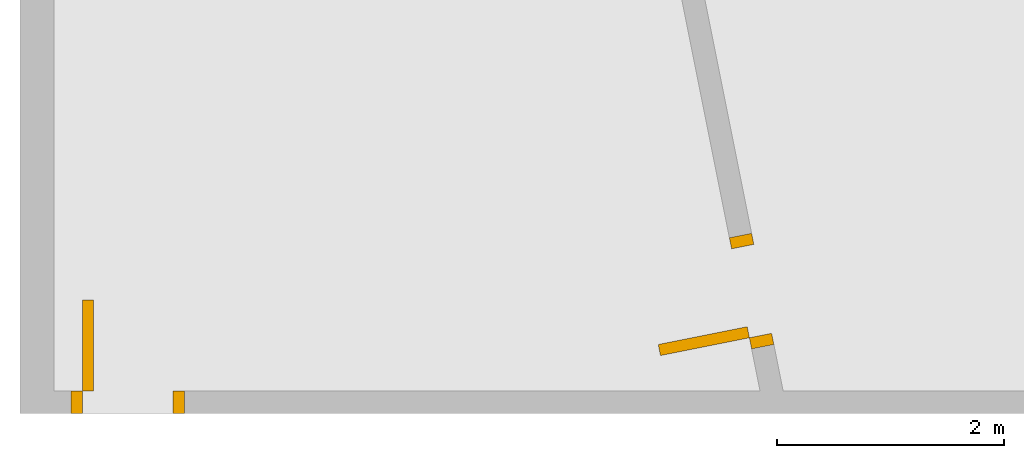
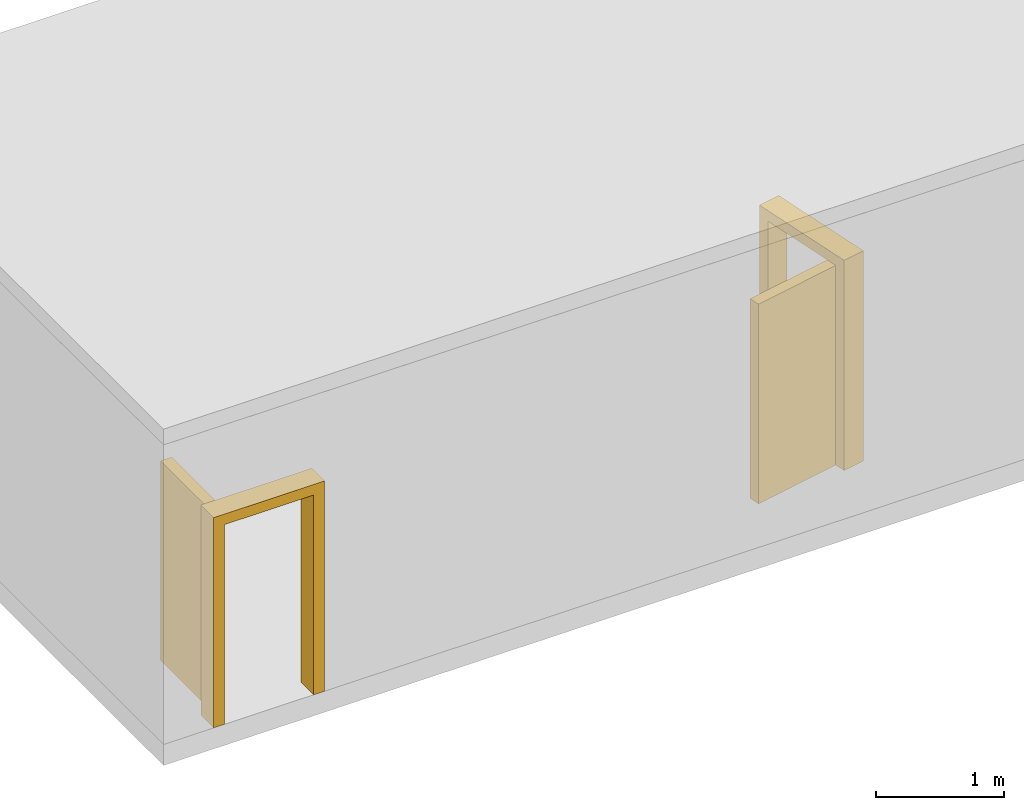
# One storey, part 2 of 3: 2 doors.
"""IFC4 building model written with IfcOpenShell, lengths in metres."""

from ifc_helpers import new_model, entity, si_unit, converted_unit, direction, origin_with_axes, place, context, subcontext, project, spatial, faceted_brep, element, save


model = new_model("IFC4")

# Units and contexts
model_context = context("Model", 3, precision=1e-05, world=origin_with_axes(), true_north=direction((0.0, 1.0)))
body_context = subcontext(model_context, "Body", "Model", "MODEL_VIEW")
ifc_project = project(units=[si_unit("LENGTHUNIT", "METRE"), si_unit("AREAUNIT", "SQUARE_METRE"), si_unit("VOLUMEUNIT", "CUBIC_METRE"), converted_unit("PLANEANGLEUNIT", "DEGREE", entity("IfcPlaneAngleMeasure", 0.017453292519943295), si_unit("PLANEANGLEUNIT", "RADIAN"), dimensions=[0, 0, 0, 0, 0, 0, 0])], contexts=[model_context])

# Building, storey
building = spatial("IfcBuilding", under=ifc_project, Name="Default Building", CompositionType="ELEMENT")
storey = spatial("IfcBuildingStorey", under=building, Name="Floor", CompositionType="COMPLEX")

# Doors
placement = place(None, origin_with_axes())
element("IfcDoor", 1, at=placement, inside=storey, Name="1100x2100_L01_01", OperationType="SINGLE_SWING_LEFT", OverallHeight=2000.0, OverallWidth=1000.0, PredefinedType="DOOR", context=body_context, shape_type="Brep", body=[
    faceted_brep([(6.48038838648618, 0.607960018928371, -1.59e-16), (6.5, 0.509901951359279, 6.8e-17), (6.30388386486182, 0.470678724331642, 0.0), (6.284272251348, 0.568736791900734, -2.27e-16), (6.10776772972363, 1.45125940002256, 2.0), (6.10776772972363, 1.45125940002256, 0.0), (6.12737934323745, 1.35320133245347, -2.27e-16), (6.12737934323745, 1.35320133245347, 1.9), (6.284272251348, 0.568736791900734, 1.9), (6.30388386486182, 0.470678724331642, 2.0), (6.48038838648618, 0.607960018928371, 1.9), (6.5, 0.509901951359279, 2.0), (6.32349547837564, 1.39242455948111, 1.9), (6.32349547837564, 1.39242455948111, -1.59e-16), (6.30388386486182, 1.4904826270502, 6.8e-17), (6.30388386486182, 1.4904826270502, 2.0)], [[[0, 1, 2, 3]], [[4, 5, 6, 7, 8, 3, 2, 9]], [[8, 10, 0, 3]], [[11, 1, 0, 10, 12, 13, 14, 15]], [[2, 1, 11, 9]], [[9, 11, 15, 4]], [[4, 15, 14, 5]], [[14, 13, 6, 5]], [[6, 13, 12, 7]], [[7, 12, 10, 8]]]),
    faceted_brep([(5.49980771079526, 0.411843883790186, -5.69e-16), (5.48019609728144, 0.509901951359278, -5.34e-16), (6.26466063783418, 0.666794859469825, -5.34e-16), (6.284272251348, 0.568736791900734, -5.69e-16), (5.49980771079526, 0.411843883790186, 1.9), (5.48019609728144, 0.509901951359278, 1.9), (6.284272251348, 0.568736791900734, 1.9), (6.26466063783418, 0.666794859469825, 1.9)], [[[0, 1, 2, 3]], [[4, 5, 1, 0]], [[6, 7, 5, 4]], [[3, 2, 7, 6]], [[6, 4, 0, 3]], [[2, 1, 5, 7]]]),
])
element("IfcDoor", 2, at=placement, inside=storey, Name="1100x2100_L01_02", OperationType="SINGLE_SWING_LEFT", OverallHeight=2000.0, OverallWidth=1000.0, PredefinedType="DOOR", context=body_context, shape_type="Brep", body=[
    faceted_brep([(0.4, -0.1, -1.39e-16), (0.3, -0.1, 8.8e-17), (0.3, 0.1, 0.0), (0.4, 0.1, -2.27e-16), (1.3, 0.1, 2.0), (1.3, 0.1, 0.0), (1.2, 0.1, -2.27e-16), (1.2, 0.1, 1.9), (0.4, 0.1, 1.9), (0.3, 0.1, 2.0), (0.4, -0.1, 1.9), (0.3, -0.1, 2.0), (1.2, -0.1, 1.9), (1.2, -0.1, -1.39e-16), (1.3, -0.1, 8.8e-17), (1.3, -0.1, 2.0)], [[[0, 1, 2, 3]], [[4, 5, 6, 7, 8, 3, 2, 9]], [[8, 10, 0, 3]], [[11, 1, 0, 10, 12, 13, 14, 15]], [[2, 1, 11, 9]], [[9, 11, 15, 4]], [[4, 15, 14, 5]], [[14, 13, 6, 5]], [[6, 13, 12, 7]], [[7, 12, 10, 8]]]),
    faceted_brep([(0.4, 0.9, -1.6e-16), (0.5, 0.9, -1.16e-16), (0.5, 0.1, -1.16e-16), (0.4, 0.1, -1.6e-16), (0.4, 0.9, 1.9), (0.5, 0.9, 1.9), (0.4, 0.1, 1.9), (0.5, 0.1, 1.9)], [[[0, 1, 2, 3]], [[4, 5, 1, 0]], [[6, 7, 5, 4]], [[3, 2, 7, 6]], [[6, 4, 0, 3]], [[2, 1, 5, 7]]]),
])

save(model, "model.ifc")
